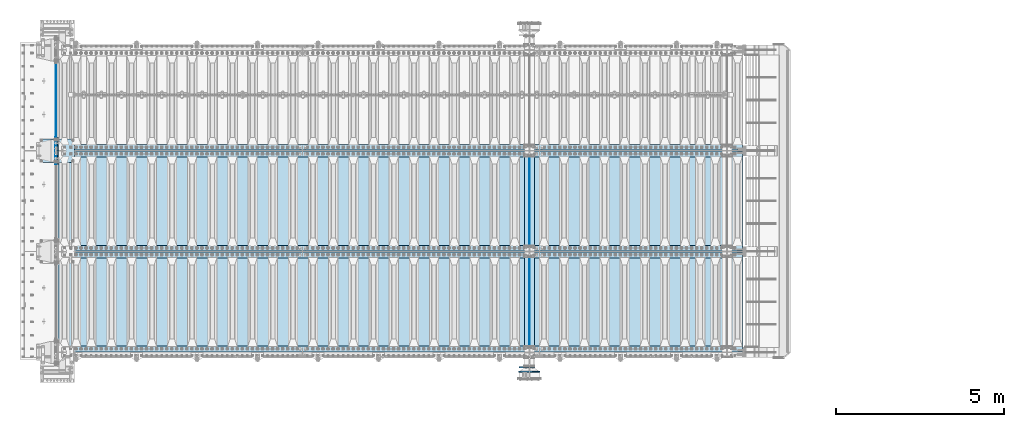
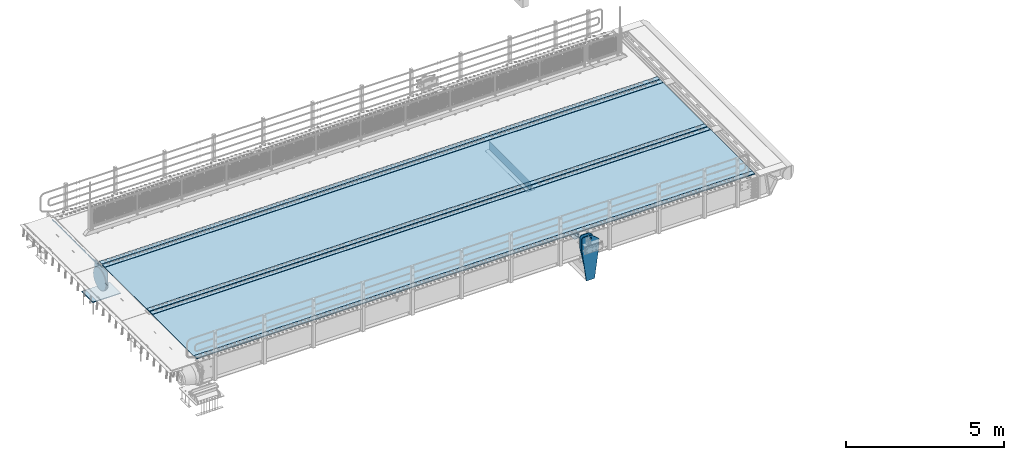
# One storey, part 211 of 270: 17 plates.
"""IFC2X3 building model written with IfcOpenShell, lengths in millimetres."""

from ifc_helpers import new_model, si_unit, frame, origin_with_axes, place, context, subcontext, project, spatial, faceted_brep, material, type_object, element, save


model = new_model("IFC2X3")

# Units and contexts
model_context = context("Model", 3, precision=1e-05, world=origin_with_axes())
body_context = subcontext(model_context, "Body", "Model", "MODEL_VIEW")
ifc_project = project(units=[si_unit("LENGTHUNIT", "METRE", prefix="MILLI"), si_unit("AREAUNIT", "SQUARE_METRE"), si_unit("VOLUMEUNIT", "CUBIC_METRE"), si_unit("MASSUNIT", "GRAM", prefix="KILO"), si_unit("TIMEUNIT", "SECOND"), si_unit("PLANEANGLEUNIT", "RADIAN"), si_unit("SOLIDANGLEUNIT", "STERADIAN"), si_unit("THERMODYNAMICTEMPERATUREUNIT", "DEGREE_CELSIUS"), si_unit("LUMINOUSINTENSITYUNIT", "LUMEN")], contexts=[model_context])

# Site, building, storey
site_placement = place(None, origin_with_axes())
site = spatial("IfcSite", under=ifc_project, at=site_placement, CompositionType="ELEMENT")
building_placement = place(site_placement, origin_with_axes())
building = spatial("IfcBuilding", under=site, at=building_placement, Name="Standard", CompositionType="ELEMENT")
storey_placement = place(building_placement, origin_with_axes())
storey = spatial("IfcBuildingStorey", under=building, at=storey_placement, Name="Undefined", CompositionType="ELEMENT", Elevation=0.0)

# Plates
ifc_material_1 = material(Name="STEEL/S355N")
plate_type_1 = type_object("IfcPlateType", PredefinedType="NOTDEFINED")
plate_1_placement = place(storey_placement, frame((-57.5, -14997.4999006275, -35.9858217417067), z_axis=(0.0, -0.999999999987744, -4.95099999993769e-06), x_axis=(0.0, 4.95100000930963e-06, -0.999999999987744)))
element("IfcPlate", 1, at=plate_1_placement, inside=storey, type_object=plate_type_1, material=ifc_material_1, context=body_context, shape_type="Brep", body=[
    faceted_brep([(-7.105427357601e-15, -7.49999999999999, 0.0), (8.68283223098842e-12, -7.49999999999999, 150.000000000004), (8.68283223098842e-12, 7.5, 150.000000000004), (-7.105427357601e-15, 7.5, 0.0), (-14.9999999999986, -7.49999999999999, 150.0), (-14.9999999999986, 7.5, 150.0), (-14.9999999999972, -7.49999999999999, 300.0), (-14.9999999999972, 7.5, 300.0), (1.55324642037158e-11, -7.49999999999999, 300.0), (1.55324642037158e-11, 7.5, 300.0), (1.87654336514242e-11, -7.49999999999999, 450.0), (1.87654336514242e-11, 7.5, 450.0), (-14.9999999999958, -7.49999999999999, 450.0), (-14.9999999999958, 7.5, 450.0), (-14.9999999999944, -7.49999999999999, 600.0), (-14.9999999999944, 7.5, 600.0), (2.74411604550551e-11, -7.49999999999999, 600.000000000004), (2.74411604550551e-11, 7.5, 600.000000000004), (3.24860138789518e-11, -7.49999999999999, 750.0), (3.24860138789518e-11, 7.5, 750.0), (-14.999999999993, -7.49999999999999, 750.0), (-14.999999999993, 7.5, 750.0), (-14.9999999999916, -7.49999999999999, 900.000000000004), (-14.9999999999916, 7.5, 900.000000000004), (4.11688461099402e-11, -7.49999999999999, 900.0), (4.11688461099402e-11, 7.5, 900.0), (4.62136995338369e-11, -7.49999999999999, 1050.0), (4.62136995338369e-11, 7.5, 1050.0), (-14.9999999999902, -7.49999999999999, 1050.0), (-14.9999999999902, 7.5, 1050.0), (-14.9999999999888, -7.49999999999999, 1200.0), (-14.9999999999888, 7.5, 1200.0), (5.30775423612795e-11, -7.49999999999999, 1200.0), (5.30775423612795e-11, 7.5, 1200.0), (5.99413851887221e-11, -7.49999999999999, 1350.0), (5.99413851887221e-11, 7.5, 1350.0), (-14.9999999999874, -7.49999999999999, 1350.0), (-14.9999999999874, 7.5, 1350.0), (-14.9999999999859, -7.49999999999999, 1500.0), (-14.9999999999859, 7.5, 1500.0), (6.49862386126188e-11, -7.49999999999999, 1500.0), (6.49862386126188e-11, 7.5, 1500.0), (7.36690708436072e-11, -7.49999999999999, 1650.0), (7.36690708436072e-11, 7.5, 1650.0), (-14.9999999999845, -7.49999999999999, 1650.0), (-14.9999999999845, 7.5, 1650.0), (-14.9999999999831, -7.49999999999999, 1800.0), (-14.9999999999831, 7.5, 1800.0), (7.68878294366004e-11, -7.49999999999999, 1800.0), (7.68878294366004e-11, 7.5, 1800.0), (8.3751672264043e-11, -7.49999999999999, 1950.0), (8.3751672264043e-11, 7.5, 1950.0), (-14.9999999999817, -7.49999999999999, 1950.0), (-14.9999999999817, 7.5, 1950.0), (-14.9999999999803, -7.49999999999999, 2100.0), (-14.9999999999803, 7.5, 2100.0), (9.06226205188432e-11, -7.49999999999999, 2100.0), (9.06226205188432e-11, 7.5, 2100.0), (9.56603685153823e-11, -7.49999999999999, 2250.0), (9.56603685153823e-11, 7.5, 2250.0), (-14.9999999999789, -7.49999999999999, 2250.0), (-14.9999999999789, 7.5, 2250.0), (-14.9999999999775, -7.49999999999999, 2400.0), (-14.9999999999775, 7.5, 2400.0), (1.04343200746371e-10, -7.49999999999999, 2400.0), (1.04343200746371e-10, 7.5, 2400.0), (1.0938094874291e-10, -7.49999999999999, 2550.0), (1.0938094874291e-10, 7.5, 2550.0), (-14.9999999999761, -7.49999999999999, 2550.0), (-14.9999999999761, 7.5, 2550.0), (-14.9999999999747, -7.49999999999999, 2700.0), (-14.9999999999747, 7.5, 2700.0), (1.14432907594164e-10, -7.49999999999999, 2700.0), (1.14432907594164e-10, 7.5, 2700.0), (1.23108634397795e-10, -7.49999999999999, 2850.0), (1.23108634397795e-10, 7.5, 2850.0), (25.0000000000267, -7.49999999999999, 2850.0), (25.0000000000267, 7.5, 2850.0), (25.0, -7.49999999999999, 0.0), (25.0, 7.5, 0.0)], [[[0, 1, 2, 3]], [[1, 4, 5, 2]], [[4, 6, 7, 5]], [[6, 8, 9, 7]], [[8, 10, 11, 9]], [[10, 12, 13, 11]], [[12, 14, 15, 13]], [[14, 16, 17, 15]], [[16, 18, 19, 17]], [[18, 20, 21, 19]], [[20, 22, 23, 21]], [[22, 24, 25, 23]], [[24, 26, 27, 25]], [[26, 28, 29, 27]], [[28, 30, 31, 29]], [[30, 32, 33, 31]], [[32, 34, 35, 33]], [[34, 36, 37, 35]], [[36, 38, 39, 37]], [[38, 40, 41, 39]], [[40, 42, 43, 41]], [[42, 44, 45, 43]], [[44, 46, 47, 45]], [[46, 48, 49, 47]], [[48, 50, 51, 49]], [[50, 52, 53, 51]], [[52, 54, 55, 53]], [[54, 56, 57, 55]], [[56, 58, 59, 57]], [[58, 60, 61, 59]], [[60, 62, 63, 61]], [[62, 64, 65, 63]], [[64, 66, 67, 65]], [[66, 68, 69, 67]], [[68, 70, 71, 69]], [[70, 72, 73, 71]], [[72, 74, 75, 73]], [[74, 76, 77, 75]], [[76, 78, 79, 77]], [[78, 0, 3, 79]], [[5, 7, 9, 11, 13, 15, 17, 19, 21, 23, 25, 27, 29, 31, 33, 35, 37, 39, 41, 43, 45, 47, 49, 51, 53, 55, 57, 59, 61, 63, 65, 67, 69, 71, 73, 75, 77, 79, 3, 2]], [[78, 76, 74, 72, 70, 68, 66, 64, 62, 60, 58, 56, 54, 52, 50, 48, 46, 44, 42, 40, 38, 36, 34, 32, 30, 28, 26, 24, 22, 20, 18, 16, 14, 12, 10, 8, 6, 4, 1, 0]]]),
])
plate_type_2 = type_object("IfcPlateType", PredefinedType="NOTDEFINED")
plate_2_placement = place(storey_placement, frame((-523.999999999993, -17650.0, -1053.0), z_axis=(1.0, 0.0, 0.0), x_axis=(0.0, -1.0, 0.0)))
element("IfcPlate", 2, at=plate_2_placement, inside=storey, type_object=plate_type_2, material=ifc_material_1, context=body_context, shape_type="Brep", body=[
    faceted_brep([(0.0, -15.0, 0.0), (2.93249286187347e-06, -15.0, 1025.0), (2.93249286187347e-06, 15.0, 1025.0), (0.0, 15.0, 0.0), (700.0, -15.0, 1025.0), (700.0, 15.0, 1025.0), (700.0, -15.0, -6.3664629124105e-12), (700.0, 15.0, -6.3664629124105e-12)], [[[0, 1, 2, 3]], [[1, 4, 5, 2]], [[4, 6, 7, 5]], [[6, 0, 3, 7]], [[5, 7, 3, 2]], [[6, 4, 1, 0]]]),
])
plate_type_3 = type_object("IfcPlateType", PredefinedType="NOTDEFINED")
for number, where, z_axis, x_axis in (
    (3, (14035.0, -18175.0, 0.0), (0.0, 0.0, -1.0), (0.0, -1.0, 0.0)),
    (4, (14035.0, -21175.0, 0.0), (0.0, 0.0, -1.0), (0.0, -1.0, 0.0)),
):
    element("IfcPlate", number, at=place(storey_placement, frame(where, z_axis=z_axis, x_axis=x_axis)), inside=storey, type_object=plate_type_3, material=ifc_material_1, context=body_context, shape_type="Brep", body=[
        faceted_brep([(0.0, -5.0, 0.0), (0.0, -5.0, 336.0), (0.0, 5.0, 336.0), (0.0, 5.0, 0.0), (2650.0, -5.0, 336.0), (2650.0, 5.0, 336.0), (2650.0, -5.0, 0.0), (2650.0, 5.0, 0.0)], [[[0, 1, 2, 3]], [[1, 4, 5, 2]], [[4, 6, 7, 5]], [[6, 0, 3, 7]], [[5, 7, 3, 2]], [[6, 4, 1, 0]]]),
    ])
plate_type_4 = type_object("IfcPlateType", PredefinedType="NOTDEFINED")
for number, where, z_axis, x_axis in (
    (5, (13885.0, -20825.0, -343.0), (0.0, 1.0, 0.0), (1.0, 0.0, 0.0)),
    (6, (13885.0, -23825.0, -343.0), (0.0, 1.0, 0.0), (1.0, 0.0, 0.0)),
):
    element("IfcPlate", number, at=place(storey_placement, frame(where, z_axis=z_axis, x_axis=x_axis)), inside=storey, type_object=plate_type_4, material=ifc_material_1, context=body_context, shape_type="Brep", body=[
        faceted_brep([(0.0, -7.0, 0.0), (0.0, -7.0, 2650.0), (0.0, 7.0, 2650.0), (0.0, 7.0, 0.0), (300.0, -7.0, 2650.0), (300.0, 7.0, 2650.0), (300.0, -7.0, 0.0), (300.0, 7.0, 0.0)], [[[0, 1, 2, 3]], [[1, 4, 5, 2]], [[4, 6, 7, 5]], [[6, 0, 3, 7]], [[5, 7, 3, 2]], [[6, 4, 1, 0]]]),
    ])
plate_type_5 = type_object("IfcPlateType", PredefinedType="NOTDEFINED")
plate_3_placement = place(storey_placement, frame((-4.99999999999636, -18400.0, -20.0), z_axis=(0.0, 1.0, 0.0), x_axis=(0.0, 0.0, -1.0)))
element("IfcPlate", 7, at=plate_3_placement, inside=storey, type_object=plate_type_5, material=ifc_material_1, context=body_context, shape_type="Brep", body=[
    faceted_brep([(855.0, -15.0, 572.963114671544), (855.0, 15.0, 572.963114671544), (849.182410261294, 15.0, 585.889268817533), (849.182410261294, -15.0, 585.889268817533), (824.193546357474, 15.0, 627.225898692486), (824.193546357474, -15.0, 627.225898692486), (794.404299268454, 15.0, 665.249063296342), (794.404299268454, -15.0, 665.249063296342), (760.249063296334, 15.0, 699.404299268463), (760.249063296334, -15.0, 699.404299268463), (722.22589869248, 15.0, 729.193546357488), (722.22589869248, -15.0, 729.193546357488), (680.889268817528, 15.0, 754.18241026131), (680.889268817528, -15.0, 754.18241026131), (636.841954817037, 15.0, 774.006497074191), (636.841954817037, -15.0, 774.006497074191), (590.726265715048, 15.0, 788.376726970451), (590.726265715048, -15.0, 788.376726970451), (543.214672102156, 15.0, 797.083549639254), (543.214672102156, -15.0, 797.083549639254), (495.0, -15.0, 800.000000000029), (495.0, 15.0, 800.0), (494.999999999412, -15.0, 0.0), (494.999999999412, 15.0, 0.0), (543.214672102129, 15.0, 2.91645036080809), (543.214672102129, -15.0, 2.91645036080809), (590.726265715023, 15.0, 11.6232730296069), (590.726265715023, -15.0, 11.6232730296069), (636.841954817014, 15.0, 25.9935029258631), (636.841954817014, -15.0, 25.9935029258631), (680.889268817507, 15.0, 45.8175897387446), (680.889268817507, -15.0, 45.8175897387446), (722.225898692462, 15.0, 70.8064536425663), (722.225898692462, -15.0, 70.8064536425663), (760.249063296318, 15.0, 100.595700731588), (760.249063296318, -15.0, 100.595700731588), (794.404299268441, 15.0, 134.750936703713), (794.404299268441, -15.0, 134.750936703713), (824.193546357463, 15.0, 172.774101307568), (824.193546357463, -15.0, 172.774101307568), (849.182410261284, 15.0, 214.110731182522), (849.182410261284, -15.0, 214.110731182522), (855.0, -15.0, 227.036885328536), (855.0, 15.0, 227.036885328536), (0.0, -15.0, 0.0), (0.0, 15.0, 0.0), (0.0, 15.0, 800.0), (0.0, -15.0, 800.0)], [[[0, 1, 2, 3]], [[3, 2, 4, 5]], [[5, 4, 6, 7]], [[7, 6, 8, 9]], [[9, 8, 10, 11]], [[11, 10, 12, 13]], [[13, 12, 14, 15]], [[15, 14, 16, 17]], [[17, 16, 18, 19]], [[20, 19, 18, 21]], [[22, 23, 24, 25]], [[25, 24, 26, 27]], [[27, 26, 28, 29]], [[29, 28, 30, 31]], [[31, 30, 32, 33]], [[33, 32, 34, 35]], [[35, 34, 36, 37]], [[37, 36, 38, 39]], [[39, 38, 40, 41]], [[42, 41, 40, 43]], [[42, 43, 1, 0]], [[44, 45, 23, 22]], [[16, 14, 12, 10, 8, 6, 4, 2, 1, 43, 40, 38, 36, 34, 32, 30, 28, 26, 24, 23, 45, 46, 21, 18]], [[44, 47, 46, 45]], [[46, 47, 20, 21]], [[47, 44, 22, 25, 27, 29, 31, 33, 35, 37, 39, 41, 42, 0, 3, 5, 7, 9, 11, 13, 15, 17, 19, 20]]]),
])
ifc_material_2 = material(Name="STEEL/S235JR")
plate_type_6 = type_object("IfcPlateType", PredefinedType="NOTDEFINED")
for number, where, z_axis, x_axis in (
    (8, (20380.0, -17985.0, 20.0), (-1.0, 0.0, 0.0), (0.0, 1.0, 0.0)),
    (9, (20380.0, -20985.0, 20.0), (-1.0, 0.0, 0.0), (0.0, 1.0, 0.0)),
    (10, (20380.0, -18185.0, 20.0), (-1.0, 0.0, 0.0), (0.0, 1.0, 0.0)),
    (11, (20380.0, -23985.0, 20.0), (-1.0, 0.0, 0.0), (0.0, 1.0, 0.0)),
    (12, (20380.0, -21185.0, 20.0), (-1.0, 0.0, 0.0), (0.0, 1.0, 0.0)),
):
    element("IfcPlate", number, at=place(storey_placement, frame(where, z_axis=z_axis, x_axis=x_axis)), inside=storey, type_object=plate_type_6, material=ifc_material_2, context=body_context, shape_type="Brep", body=[
        faceted_brep([(0.0, -6.0, 0.0), (0.0, -6.0, 20360.0), (0.0, 6.0, 20360.0), (0.0, 6.0, 0.0), (170.0, -6.0, 20360.0), (170.0, 6.0, 20360.0), (170.0, -6.0, 0.0), (170.0, 6.0, 0.0)], [[[0, 1, 2, 3]], [[1, 4, 5, 2]], [[4, 6, 7, 5]], [[6, 0, 3, 7]], [[5, 7, 3, 2]], [[6, 4, 1, 0]]]),
    ])
plate_type_7 = type_object("IfcPlateType", PredefinedType="NOTDEFINED")
for number, where, z_axis, x_axis in (
    (13, (10.0, -18005.0, 7.0), (1.0, 0.0, 0.0), (0.0, -1.0, 0.0)),
    (14, (10.0, -21005.0, 7.0), (1.0, 0.0, 0.0), (0.0, -1.0, 0.0)),
):
    element("IfcPlate", number, at=place(storey_placement, frame(where, z_axis=z_axis, x_axis=x_axis)), inside=storey, type_object=plate_type_7, material=ifc_material_1, context=body_context, shape_type="Brep", body=[
        faceted_brep([(0.0, -7.0, 0.0), (-2.96859070658684e-09, -7.0, 20380.0), (-2.96859070658684e-09, 7.0, 20380.0), (0.0, 7.0, 0.0), (2990.0, -7.0, 20380.0), (2990.0, 7.0, 20380.0), (2990.0, -7.0, 0.0), (2990.0, 7.0, 0.0)], [[[0, 1, 2, 3]], [[1, 4, 5, 2]], [[4, 6, 7, 5]], [[6, 0, 3, 7]], [[5, 7, 3, 2]], [[6, 4, 1, 0]]]),
    ])
plate_type_8 = type_object("IfcPlateType", PredefinedType="NOTDEFINED")
plate_4_placement = place(storey_placement, frame((14195.0000000199, -24440.0000000458, -955.000018245424), z_axis=(-0.901283188008788, 0.0, 0.433230441004225), x_axis=(-0.433230441004224, 0.0, -0.901283188008789)))
element("IfcPlate", 15, at=plate_4_placement, inside=storey, type_object=plate_type_8, material=ifc_material_1, context=body_context, shape_type="Brep", body=[
    faceted_brep([(22.0942403454173, -15.0000000000055, 175.225838699631), (22.0942403454173, 14.9999999999927, 175.225838699631), (270.84840339248, 15.0, 55.6542354651265), (270.84840339248, -15.0, 55.6542354651265), (15.595783730354, -15.0000000000055, 161.706590879499), (15.595783730354, 14.9999999999927, 161.706590879499), (264.349945979715, -15.0, 42.1349880284361), (264.349945979715, 15.0, 42.1349880284361), (244.096420288086, -15.0, -5.45696821063757e-11), (244.096420288086, 15.0, -5.45696821063757e-11), (0.0, -15.0, 0.0), (0.0, 15.0, 0.0), (-976.801818847657, -15.0000000000036, 469.530853271483), (-976.801818847657, 14.9999999999964, 469.530853271484), (-1005.61098604242, -15.0000000000036, 584.572481266789), (-1005.61098604242, 14.9999999999964, 584.57248126679), (-1008.62084772112, -15.0, 603.379189822304), (-1008.62084772112, 15.0, 603.379189822303), (-1008.34151554697, -15.0, 622.42317909855), (-1008.34151554697, 15.0, 622.423179098552), (-1004.7813898293, -15.0, 641.133500175492), (-1004.7813898293, 15.0, 641.133500175492), (-998.04713292392, -15.0, 658.949304871174), (-998.04713292392, 15.0, 658.949304871174), (-903.393050005924, -15.0, 855.86569143182), (-903.393050005923, 15.0, 855.86569143182), (-891.965949445595, -15.0000000000036, 873.346281101725), (-891.965949445595, 14.9999999999964, 873.346281101725), (-876.403907448141, -15.0000000000036, 887.273681838964), (-876.403907448141, 14.9999999999964, 887.273681838964), (-857.76745199059, -15.0000000000036, 896.698763822953), (-857.76745199059, 14.9999999999964, 896.698763822949), (-837.326627351686, -15.0, 900.979222969756), (-837.326627351686, 15.0, 900.979222969754), (-816.474442649736, -15.0, 899.823352915888), (-816.474442649736, 15.0, 899.823352915888), (-796.631940525474, -15.0, 893.309924335019), (-796.631940525474, 15.0, 893.309924335019), (-427.105804443361, -15.0, 715.685363769531), (-427.105804443361, 15.0, 715.685363769529), (138.633743286133, -15.0, 288.410614013672), (138.633743286133, 15.0, 288.410614013672), (291.101928710938, -15.0, 97.7892227172833), (291.101928710938, 15.0, 97.7892227172833), (-886.324025694375, -15.0000000000073, 572.182288694508), (-886.324025694375, 14.9999999999927, 572.182288694508), (-901.776420284151, 14.9999999999927, 569.98934605829), (-901.776420284151, -15.0000000000073, 569.98934605829), (-872.8870774196, -15.0000000000073, 580.121678911955), (-872.8870774196, 14.9999999999927, 580.121678911955), (-863.511229028421, -15.0000000000073, 592.598816520776), (-863.511229028421, 14.9999999999927, 592.598816520776), (-859.623868446117, -15.0000000000073, 607.714170425566), (-859.623868446117, 14.9999999999927, 607.714170425566), (-861.816811082333, -15.0000000000073, 623.166565015343), (-861.816811082333, 14.9999999999927, 623.166565015343), (-869.75620129978, -15.0000000000073, 636.603513290118), (-869.75620129978, 14.9999999999927, 636.603513290118), (-882.233338908602, -15.0000000000073, 645.979361681297), (-882.233338908602, 14.9999999999927, 645.979361681297), (-897.348692813393, -15.0000000000073, 649.866722263601), (-897.348692813393, 14.9999999999927, 649.866722263601), (-912.801087403169, -15.0000000000073, 647.673779627385), (-912.801087403169, 14.9999999999927, 647.673779627385), (-926.238035677944, -15.0000000000073, 639.734389409938), (-926.238035677944, 14.9999999999927, 639.734389409938), (-935.613884069124, -15.0000000000073, 627.257251801115), (-935.613884069124, 14.9999999999927, 627.257251801115), (-939.501244651427, -15.0000000000073, 612.141897896327), (-939.501244651427, 14.9999999999927, 612.141897896327), (-937.308302015211, -15.0000000000073, 596.68950330655), (-937.308302015211, 14.9999999999927, 596.68950330655), (-929.368911797764, -15.0000000000073, 583.252555031773), (-929.368911797764, 14.9999999999927, 583.252555031773), (-916.891774188941, -15.0000000000073, 573.876706640594), (-916.891774188941, 14.9999999999927, 573.876706640594), (-844.133640470461, 15.0, 583.284362049932), (-843.858297554222, 15.0, 588.251621180299), (-847.17598332599, 15.0, 591.958700638515), (-852.143242456357, 15.0, 592.234043554756), (-855.850321914575, 15.0, 588.916357782986), (-856.125664830814, 15.0, 583.94909865262), (-852.807979059045, 15.0, 580.2420191944), (-847.840719928679, 15.0, 579.966676278164), (-847.840719928679, -15.0, 579.966676278164), (-852.807979059045, -15.0, 580.2420191944), (-844.133640470461, -15.0, 583.284362049932), (-843.858297554222, -15.0, 588.251621180299), (-847.17598332599, -15.0, 591.958700638515), (-852.143242456357, -15.0, 592.234043554756), (-855.850321914575, -15.0, 588.916357782986), (-856.125664830814, -15.0, 583.94909865262)], [[[0, 1, 2, 3]], [[4, 5, 1, 0]], [[6, 7, 5, 4]], [[8, 9, 7, 6]], [[8, 10, 11, 9]], [[10, 12, 13, 11]], [[12, 14, 15, 13]], [[14, 16, 17, 15]], [[16, 18, 19, 17]], [[18, 20, 21, 19]], [[20, 22, 23, 21]], [[22, 24, 25, 23]], [[24, 26, 27, 25]], [[26, 28, 29, 27]], [[28, 30, 31, 29]], [[30, 32, 33, 31]], [[32, 34, 35, 33]], [[34, 36, 37, 35]], [[36, 38, 39, 37]], [[38, 40, 41, 39]], [[40, 42, 43, 41]], [[43, 42, 3, 2]], [[44, 45, 46, 47]], [[48, 49, 45, 44]], [[50, 51, 49, 48]], [[52, 53, 51, 50]], [[54, 55, 53, 52]], [[56, 57, 55, 54]], [[58, 59, 57, 56]], [[60, 61, 59, 58]], [[62, 63, 61, 60]], [[64, 65, 63, 62]], [[66, 67, 65, 64]], [[68, 69, 67, 66]], [[70, 71, 69, 68]], [[72, 73, 71, 70]], [[74, 75, 73, 72]], [[47, 46, 75, 74]], [[9, 11, 13, 15, 17, 19, 21, 23, 25, 27, 29, 31, 33, 35, 37, 39, 41, 43, 2, 1, 5, 7], [76, 77, 78, 79, 80, 81, 82, 83], [45, 49, 51, 53, 55, 57, 59, 61, 63, 65, 67, 69, 71, 73, 75, 46]], [[84, 83, 82, 85]], [[86, 76, 83, 84]], [[87, 77, 76, 86]], [[88, 78, 77, 87]], [[89, 79, 78, 88]], [[90, 80, 79, 89]], [[91, 81, 80, 90]], [[85, 82, 81, 91]], [[3, 42, 40, 38, 36, 34, 32, 30, 28, 26, 24, 22, 20, 18, 16, 14, 12, 10, 8, 6, 4, 0], [90, 89, 88, 87, 86, 84, 85, 91], [70, 68, 66, 64, 62, 60, 58, 56, 54, 52, 50, 48, 44, 47, 74, 72]]]),
])
plate_type_9 = type_object("IfcPlateType", PredefinedType="NOTDEFINED")
plate_5_placement = place(storey_placement, frame((14185.0000000064, -24580.0000000458, -1480.00001823894), z_axis=(0.0, 0.0, 1.0), x_axis=(-1.0, 0.0, 0.0)))
element("IfcPlate", 16, at=plate_5_placement, inside=storey, type_object=plate_type_9, material=ifc_material_1, context=body_context, shape_type="Brep", body=[
    faceted_brep([(145.403805922693, -15.0, 1549.59619407771), (145.403805922693, 15.0, 1549.59619407771), (150.000000000406, 15.0, 1551.5), (150.000000000406, -15.0, 1551.5), (154.596194078118, 15.0, 1549.59619407771), (154.596194078118, -15.0, 1549.59619407771), (156.500000000406, 15.0, 1545.0), (156.500000000406, -15.0, 1545.0), (154.596194078118, 15.0, 1540.40380592229), (154.596194078118, -15.0, 1540.40380592229), (150.000000000406, 15.0, 1538.5), (150.000000000406, -15.0, 1538.5), (145.403805922693, 15.0, 1540.40380592229), (145.403805922693, -15.0, 1540.40380592229), (143.500000000406, 15.0, 1545.0), (143.500000000406, -15.0, 1545.0), (300.0, -15.0, 0.0), (0.0, -15.0, 0.0), (0.0, 15.0, 0.0), (300.0, 15.0, 0.0), (462.5, -15.0, 1210.0), (462.5, 15.0, 1210.0), (462.5, -15.0, 1630.0), (462.5, 15.0, 1630.0), (459.774066103126, -15.0, 1650.7055236082), (459.774066103126, 15.0, 1650.7055236082), (451.782032302755, -15.0, 1670.0), (451.782032302755, 15.0, 1670.0), (439.068542494924, -15.0, 1686.56854249492), (439.068542494924, 15.0, 1686.56854249492), (422.5, -15.0, 1699.28203230276), (422.5, 15.0, 1699.28203230276), (403.205523608201, -15.0, 1707.27406610313), (403.205523608201, 15.0, 1707.27406610313), (382.5, -15.0, 1710.0), (382.5, 15.0, 1710.0), (151.788081037079, -15.0, 1710.0), (151.788081037079, 15.0, 1710.0), (132.694887325031, -15.0, 1708.33028179541), (132.694887325031, 15.0, 1708.33028179541), (114.181334578885, -15.0, 1703.37181734316), (114.181334578885, 15.0, 1703.37181734316), (96.8094667268542, -15.0, 1695.27513824985), (96.8094667268542, 15.0, 1695.27513824985), (81.1066678416755, -15.0, 1684.28604765144), (81.1066678416755, 15.0, 1684.28604765144), (-162.5, -15.0, 1480.0), (-162.5, 15.0, 1480.0), (-162.5, -15.0, 1210.0), (-162.5, 15.0, 1210.0), (121.715728752944, -15.0, 1628.28427124746), (134.692662705802, -15.0, 1636.95518130045), (150.000000000406, -15.0, 1640.0), (165.307337295009, -15.0, 1636.95518130045), (178.284271247867, -15.0, 1628.28427124746), (186.955181300857, -15.0, 1615.3073372946), (190.000000000406, -15.0, 1600.0), (186.955181300857, -15.0, 1584.6926627054), (178.284271247867, -15.0, 1571.71572875254), (165.307337295009, -15.0, 1563.04481869955), (150.000000000406, -15.0, 1560.0), (134.692662705802, -15.0, 1563.04481869955), (121.715728752944, -15.0, 1571.71572875254), (113.044818699955, -15.0, 1584.6926627054), (110.000000000406, -15.0, 1600.0), (113.044818699955, -15.0, 1615.3073372946), (121.715728752944, 14.9999999999527, 1571.71572875254), (113.044818699955, 14.9999999999527, 1584.6926627054), (134.692662705802, 14.9999999999527, 1563.04481869955), (150.000000000406, 14.9999999999527, 1560.0), (165.307337295009, 14.9999999999527, 1563.04481869955), (178.284271247867, 14.9999999999527, 1571.71572875254), (186.955181300857, 14.9999999999527, 1584.6926627054), (190.000000000406, 14.9999999999527, 1600.0), (186.955181300857, 14.9999999999527, 1615.3073372946), (178.284271247867, 14.9999999999527, 1628.28427124746), (165.307337295009, 14.9999999999527, 1636.95518130045), (150.000000000406, 14.9999999999527, 1640.0), (134.692662705802, 14.9999999999527, 1636.95518130045), (121.715728752944, 14.9999999999527, 1628.28427124746), (113.044818699955, 14.9999999999527, 1615.3073372946), (110.000000000406, 14.9999999999527, 1600.0)], [[[0, 1, 2, 3]], [[3, 2, 4, 5]], [[5, 4, 6, 7]], [[7, 6, 8, 9]], [[9, 8, 10, 11]], [[11, 10, 12, 13]], [[13, 12, 14, 15]], [[15, 14, 1, 0]], [[16, 17, 18, 19]], [[20, 16, 19, 21]], [[22, 20, 21, 23]], [[24, 22, 23, 25]], [[26, 24, 25, 27]], [[28, 26, 27, 29]], [[30, 28, 29, 31]], [[32, 30, 31, 33]], [[34, 32, 33, 35]], [[36, 34, 35, 37]], [[38, 36, 37, 39]], [[40, 38, 39, 41]], [[42, 40, 41, 43]], [[44, 42, 43, 45]], [[46, 44, 45, 47]], [[48, 46, 47, 49]], [[17, 48, 49, 18]], [[16, 20, 22, 24, 26, 28, 30, 32, 34, 36, 38, 40, 42, 44, 46, 48, 17], [3, 5, 7, 9, 11, 13, 15, 0], [50, 51, 52, 53, 54, 55, 56, 57, 58, 59, 60, 61, 62, 63, 64, 65]], [[62, 66, 67, 63]], [[61, 68, 66, 62]], [[60, 69, 68, 61]], [[59, 70, 69, 60]], [[58, 71, 70, 59]], [[57, 72, 71, 58]], [[56, 73, 72, 57]], [[55, 74, 73, 56]], [[54, 75, 74, 55]], [[53, 76, 75, 54]], [[52, 77, 76, 53]], [[51, 78, 77, 52]], [[50, 79, 78, 51]], [[65, 80, 79, 50]], [[64, 81, 80, 65]], [[63, 67, 81, 64]], [[47, 45, 43, 41, 39, 37, 35, 33, 31, 29, 27, 25, 23, 21, 19, 18, 49], [10, 8, 6, 4, 2, 1, 14, 12], [66, 68, 69, 70, 71, 72, 73, 74, 75, 76, 77, 78, 79, 80, 81, 67]]]),
])
plate_type_10 = type_object("IfcPlateType", PredefinedType="NOTDEFINED")
plate_6_placement = place(storey_placement, frame((-62.5000000000001, -17600.0, -114.999999999998), z_axis=(0.0, 0.0, -1.0), x_axis=(0.0, -1.0, 0.0)))
element("IfcPlate", 17, at=plate_6_placement, inside=storey, type_object=plate_type_10, material=ifc_material_1, context=body_context, shape_type="Brep", body=[
    faceted_brep([(0.0, -12.5, 400.0), (2.91645036077898, -12.5, 448.214672102129), (2.91645036077898, 12.5, 448.214672102129), (0.0, 12.5, 400.0), (11.6232730295797, -12.5, 495.726265715023), (11.6232730295797, 12.5, 495.726265715023), (25.993502925834, -12.5, 541.841954817014), (25.993502925834, 12.5, 541.841954817014), (45.8175897387155, -12.5, 585.889268817507), (45.8175897387155, 12.5, 585.889268817507), (70.8064536425372, -12.5, 627.225898692462), (70.8064536425372, 12.5, 627.225898692462), (100.595700731559, -12.5, 665.249063296318), (100.595700731559, 12.5, 665.249063296318), (134.750936703682, -12.5, 699.40429926844), (134.750936703682, 12.5, 699.40429926844), (172.774101307537, -12.5, 729.193546357462), (172.774101307537, 12.5, 729.193546357462), (214.110731182493, -12.5, 754.182410261284), (214.110731182493, 12.5, 754.182410261284), (258.158045182985, -12.5, 774.006497074166), (258.158045182985, 12.5, 774.006497074166), (304.273734284976, -12.5, 788.376726970421), (304.273734284976, 12.5, 788.376726970421), (351.785327897871, -12.5, 797.083549639221), (351.785327897871, 12.5, 797.083549639221), (400.0, -12.5, 800.0), (400.0, 12.5, 800.0), (448.214672102129, -12.5, 797.083549639222), (448.214672102129, 12.5, 797.083549639222), (495.726265715022, -12.5, 788.376726970421), (495.726265715022, 12.5, 788.376726970421), (541.841954817013, -12.5, 774.006497074166), (541.841954817013, 12.5, 774.006497074166), (585.889268817507, -12.5, 754.182410261284), (585.889268817507, 12.5, 754.182410261284), (627.225898692463, -12.5, 729.193546357463), (627.225898692463, 12.5, 729.193546357463), (665.249063296318, -12.5, 699.404299268441), (665.249063296318, 12.5, 699.404299268441), (699.404299268441, -12.5, 665.249063296318), (699.404299268441, 12.5, 665.249063296318), (729.193546357463, -12.5, 627.225898692462), (729.193546357463, 12.5, 627.225898692462), (754.182410261285, -12.5, 585.889268817507), (754.182410261285, 12.5, 585.889268817507), (774.006497074166, -12.5, 541.841954817014), (774.006497074166, 12.5, 541.841954817014), (788.37672697042, -12.5, 495.726265715023), (788.37672697042, 12.5, 495.726265715023), (797.083549639221, -12.5, 448.214672102129), (797.083549639221, 12.5, 448.214672102129), (800.0, -12.5, 400.0), (800.0, 12.5, 400.0), (797.083549639221, -12.5, 351.785327897871), (797.083549639221, 12.5, 351.785327897871), (788.37672697042, -12.5, 304.273734284977), (788.37672697042, 12.5, 304.273734284977), (774.006497074166, -12.5, 258.158045182986), (774.006497074166, 12.5, 258.158045182986), (754.182410261285, -12.5, 214.110731182493), (754.182410261285, 12.5, 214.110731182493), (729.193546357463, -12.5, 172.774101307538), (729.193546357463, 12.5, 172.774101307538), (699.404299268441, -12.5, 134.750936703682), (699.404299268441, 12.5, 134.750936703682), (665.249063296318, -12.5, 100.59570073156), (665.249063296318, 12.5, 100.59570073156), (627.225898692463, -12.5, 70.8064536425375), (627.225898692463, 12.5, 70.8064536425375), (585.889268817507, -12.5, 45.817589738716), (585.889268817507, 12.5, 45.817589738716), (541.841954817015, -12.5, 25.9935029258342), (541.841954817015, 12.5, 25.9935029258342), (495.726265715024, -12.5, 11.6232730295793), (495.726265715024, 12.5, 11.6232730295793), (448.214672102129, -12.5, 2.91645036077847), (448.214672102129, 12.5, 2.91645036077847), (400.0, -12.5, -5.6843418860808e-14), (400.0, 12.5, -5.6843418860808e-14), (351.785327897871, -12.5, 2.91645036077836), (351.785327897871, 12.5, 2.91645036077836), (304.273734284976, -12.5, 11.6232730295792), (304.273734284976, 12.5, 11.6232730295792), (258.158045182985, -12.5, 25.993502925834), (258.158045182985, 12.5, 25.993502925834), (214.110731182493, -12.5, 45.817589738716), (214.110731182493, 12.5, 45.817589738716), (172.774101307537, -12.5, 70.8064536425374), (172.774101307537, 12.5, 70.8064536425374), (134.750936703682, -12.5, 100.595700731559), (134.750936703682, 12.5, 100.595700731559), (100.595700731559, -12.5, 134.750936703682), (100.595700731559, 12.5, 134.750936703682), (70.8064536425372, -12.5, 172.774101307538), (70.8064536425372, 12.5, 172.774101307538), (45.8175897387155, -12.5, 214.110731182492), (45.8175897387155, 12.5, 214.110731182492), (25.993502925834, -12.5, 258.158045182986), (25.993502925834, 12.5, 258.158045182986), (11.6232730295797, -12.5, 304.273734284977), (11.6232730295797, 12.5, 304.273734284977), (2.91645036077898, -12.5, 351.785327897871), (2.91645036077898, 12.5, 351.785327897871)], [[[0, 1, 2, 3]], [[1, 4, 5, 2]], [[4, 6, 7, 5]], [[6, 8, 9, 7]], [[8, 10, 11, 9]], [[10, 12, 13, 11]], [[12, 14, 15, 13]], [[14, 16, 17, 15]], [[16, 18, 19, 17]], [[18, 20, 21, 19]], [[20, 22, 23, 21]], [[22, 24, 25, 23]], [[24, 26, 27, 25]], [[26, 28, 29, 27]], [[28, 30, 31, 29]], [[30, 32, 33, 31]], [[32, 34, 35, 33]], [[34, 36, 37, 35]], [[36, 38, 39, 37]], [[38, 40, 41, 39]], [[40, 42, 43, 41]], [[42, 44, 45, 43]], [[44, 46, 47, 45]], [[46, 48, 49, 47]], [[48, 50, 51, 49]], [[50, 52, 53, 51]], [[52, 54, 55, 53]], [[54, 56, 57, 55]], [[56, 58, 59, 57]], [[58, 60, 61, 59]], [[60, 62, 63, 61]], [[62, 64, 65, 63]], [[64, 66, 67, 65]], [[66, 68, 69, 67]], [[68, 70, 71, 69]], [[70, 72, 73, 71]], [[72, 74, 75, 73]], [[74, 76, 77, 75]], [[76, 78, 79, 77]], [[78, 80, 81, 79]], [[80, 82, 83, 81]], [[82, 84, 85, 83]], [[84, 86, 87, 85]], [[86, 88, 89, 87]], [[88, 90, 91, 89]], [[90, 92, 93, 91]], [[92, 94, 95, 93]], [[94, 96, 97, 95]], [[96, 98, 99, 97]], [[98, 100, 101, 99]], [[100, 102, 103, 101]], [[102, 0, 3, 103]], [[5, 7, 9, 11, 13, 15, 17, 19, 21, 23, 25, 27, 29, 31, 33, 35, 37, 39, 41, 43, 45, 47, 49, 51, 53, 55, 57, 59, 61, 63, 65, 67, 69, 71, 73, 75, 77, 79, 81, 83, 85, 87, 89, 91, 93, 95, 97, 99, 101, 103, 3, 2]], [[102, 100, 98, 96, 94, 92, 90, 88, 86, 84, 82, 80, 78, 76, 74, 72, 70, 68, 66, 64, 62, 60, 58, 56, 54, 52, 50, 48, 46, 44, 42, 40, 38, 36, 34, 32, 30, 28, 26, 24, 22, 20, 18, 16, 14, 12, 10, 8, 6, 4, 1, 0]]]),
])

save(model, "model.ifc")
